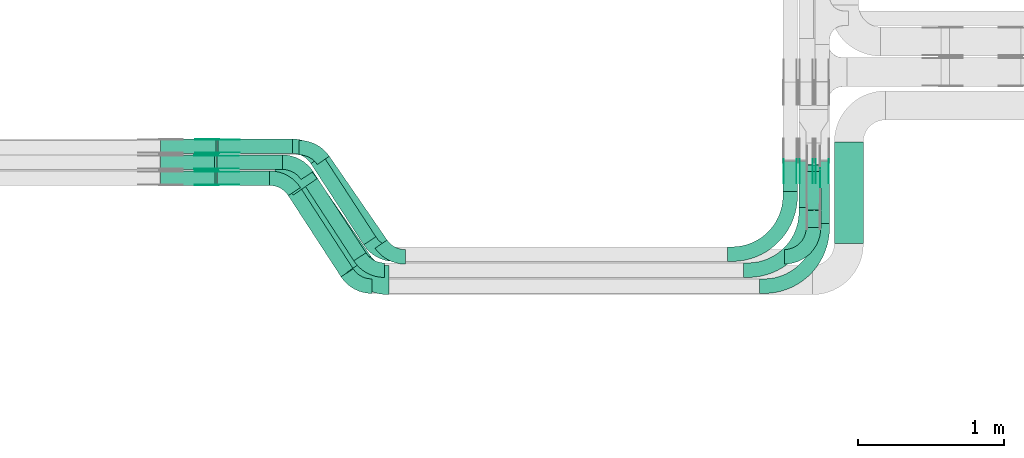
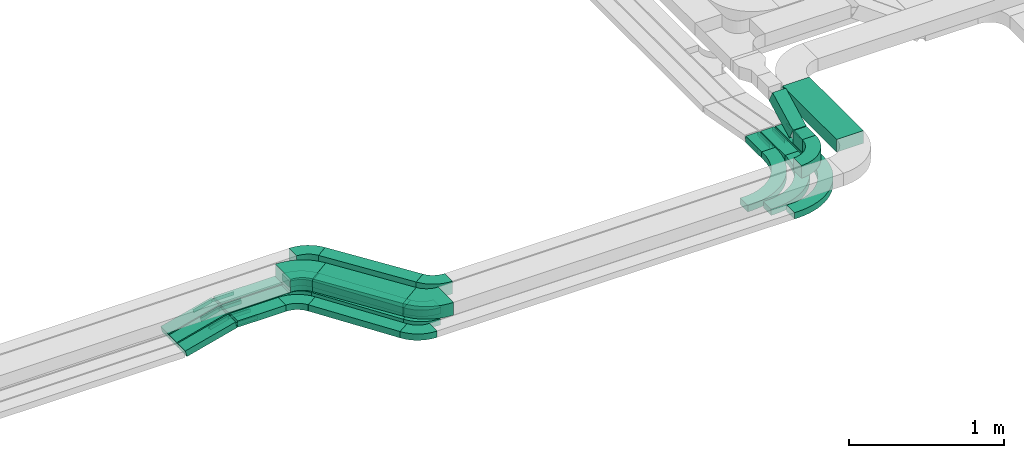
# One storey, part 9 of 23: 33 flow fittings, 17 flow segments.
"""IFC2X3 building model written with IfcOpenShell, lengths in millimetres."""

from ifc_helpers import new_model, entity, si_unit, converted_unit, derived_unit, direction, frame, frame_2d, origin, origin_2d_with_axis, place, context, subcontext, project, spatial, polyline, circle_curve, parameter, trimmed, segment, composite_curve, rectangle, outline, extrude, source, transform, mapped, material, type_object, type_shapes, element, save


model = new_model("IFC2X3")

# Units and contexts
model_context = context("Model", 3, precision=0.01, world=origin(), true_north=direction((6.12303176911189e-17, 1.0)))
body_context = subcontext(model_context, "Body", "Model", "MODEL_VIEW")
ifc_project = project(units=[si_unit("LENGTHUNIT", "METRE", prefix="MILLI"), si_unit("AREAUNIT", "SQUARE_METRE"), si_unit("VOLUMEUNIT", "CUBIC_METRE"), converted_unit("PLANEANGLEUNIT", "DEGREE", entity("IfcRatioMeasure", 0.0174532925199433), si_unit("PLANEANGLEUNIT", "RADIAN"), dimensions=[0, 0, 0, 0, 0, 0, 0]), si_unit("MASSUNIT", "GRAM", prefix="KILO"), derived_unit("MASSDENSITYUNIT", [(si_unit("MASSUNIT", "GRAM", prefix="KILO"), 1), (si_unit("LENGTHUNIT", "METRE"), -3)]), derived_unit("MOMENTOFINERTIAUNIT", [(si_unit("LENGTHUNIT", "METRE"), 4)]), si_unit("TIMEUNIT", "SECOND"), si_unit("FREQUENCYUNIT", "HERTZ"), si_unit("THERMODYNAMICTEMPERATUREUNIT", "DEGREE_CELSIUS"), derived_unit("THERMALTRANSMITTANCEUNIT", [(si_unit("MASSUNIT", "GRAM", prefix="KILO"), 1), (si_unit("THERMODYNAMICTEMPERATUREUNIT", "KELVIN"), -1), (si_unit("TIMEUNIT", "SECOND"), -3)]), derived_unit("VOLUMETRICFLOWRATEUNIT", [(si_unit("LENGTHUNIT", "METRE"), 3), (si_unit("TIMEUNIT", "SECOND"), -1)]), derived_unit("MASSFLOWRATEUNIT", [(si_unit("MASSUNIT", "GRAM", prefix="KILO"), 1), (si_unit("TIMEUNIT", "SECOND"), -1)]), derived_unit("ROTATIONALFREQUENCYUNIT", [(si_unit("TIMEUNIT", "SECOND"), -1)]), si_unit("ELECTRICCURRENTUNIT", "AMPERE"), si_unit("ELECTRICVOLTAGEUNIT", "VOLT"), si_unit("POWERUNIT", "WATT"), si_unit("FORCEUNIT", "NEWTON", prefix="KILO"), si_unit("ILLUMINANCEUNIT", "LUX"), si_unit("LUMINOUSFLUXUNIT", "LUMEN"), si_unit("LUMINOUSINTENSITYUNIT", "CANDELA"), derived_unit("USERDEFINED", [(si_unit("MASSUNIT", "GRAM", prefix="KILO"), -1), (si_unit("LENGTHUNIT", "METRE"), -2), (si_unit("TIMEUNIT", "SECOND"), 3), (si_unit("LUMINOUSFLUXUNIT", "LUMEN"), 1)]), derived_unit("LINEARVELOCITYUNIT", [(si_unit("LENGTHUNIT", "METRE"), 1), (si_unit("TIMEUNIT", "SECOND"), -1)]), si_unit("PRESSUREUNIT", "PASCAL"), derived_unit("USERDEFINED", [(si_unit("LENGTHUNIT", "METRE"), -2), (si_unit("MASSUNIT", "GRAM", prefix="KILO"), 1), (si_unit("TIMEUNIT", "SECOND"), -2)]), derived_unit("LINEARFORCEUNIT", [(si_unit("MASSUNIT", "GRAM", prefix="KILO"), 1), (si_unit("LENGTHUNIT", "METRE"), 1), (si_unit("TIMEUNIT", "SECOND"), -2), (si_unit("LENGTHUNIT", "METRE"), -1)]), derived_unit("PLANARFORCEUNIT", [(si_unit("MASSUNIT", "GRAM", prefix="KILO"), 1), (si_unit("LENGTHUNIT", "METRE"), 1), (si_unit("TIMEUNIT", "SECOND"), -2), (si_unit("LENGTHUNIT", "METRE"), -2)])], contexts=[model_context])

# Site, building, storey
site_placement = place(None, origin())
site = spatial("IfcSite", under=ifc_project, at=site_placement, CompositionType="ELEMENT")
building_placement = place(site_placement, origin())
building = spatial("IfcBuilding", under=site, at=building_placement, CompositionType="ELEMENT")
storey_placement = place(building_placement, frame((0.0, 0.0, 24000.0)))
storey = spatial("IfcBuildingStorey", under=building, at=storey_placement, CompositionType="ELEMENT", Elevation=24000.0)

# Flow segments
cable_carrier_segment_type = type_object("IfcCableCarrierSegmentType", PredefinedType="CABLETRAYSEGMENT")
flow_segment_1_placement = place(storey_placement, frame((28945.08, 10007.82, 2750.0)))
element("IfcFlowSegment", 1, at=flow_segment_1_placement, inside=storey, type_object=cable_carrier_segment_type, context=body_context, shape_type="SweptSolid", body=[
    extrude(rectangle(XDim=449.703961054591, YDim=99.9999999999989, at=origin_2d_with_axis()), frame((224.85, 50.0, 0.0)), (0.0, 0.0, 1.0), 49.9999999999931),
])
flow_segment_2_placement = place(storey_placement, frame((28952.89, 10117.82, 2750.0)))
element("IfcFlowSegment", 2, at=flow_segment_2_placement, inside=storey, type_object=cable_carrier_segment_type, context=body_context, shape_type="SweptSolid", body=[
    extrude(rectangle(XDim=509.777434753036, YDim=99.9999999999989, at=origin_2d_with_axis()), frame((254.89, 50.0, 0.0)), (0.0, 0.0, 1.0), 49.9999999999974),
])
flow_segment_3_placement = place(storey_placement, frame((29589.98, 9490.7, 2750.0)))
element("IfcFlowSegment", 3, at=flow_segment_3_placement, inside=storey, type_object=cable_carrier_segment_type, context=body_context, shape_type="SweptSolid", body=[
    extrude(rectangle(XDim=665.559579029172, YDim=100.000000000004, at=origin_2d_with_axis()), frame((223.28, 306.27, 0.0), z_axis=(5.11388203057767e-09, -7.86751081627487e-09, 1.0), x_axis=(0.544988350595341, -0.838443616300685, -9.38347035306593e-09)), (0.0, 0.0, 1.0), 49.9999999999973),
])
flow_segment_4_placement = place(storey_placement, frame((29634.49, 9466.73, 2890.0)))
element("IfcFlowSegment", 4, at=flow_segment_4_placement, inside=storey, type_object=cable_carrier_segment_type, context=body_context, shape_type="SweptSolid", body=[
    extrude(rectangle(XDim=698.971890855876, YDim=99.9999999999974, at=origin_2d_with_axis()), frame((239.56, 316.1, 0.0), z_axis=(0.0, 0.0, 1.0), x_axis=(0.567682967884993, -0.823247258102501, 0.0)), (0.0, 0.0, 1.0), 100.000000000003),
])
flow_segment_5_placement = place(storey_placement, frame((28948.31, 9897.82, 2750.0)))
element("IfcFlowSegment", 5, at=flow_segment_5_placement, inside=storey, type_object=cable_carrier_segment_type, context=body_context, shape_type="SweptSolid", body=[
    extrude(rectangle(XDim=359.081105196311, YDim=99.9999999999989, at=origin_2d_with_axis()), frame((179.54, 50.0, 0.0)), (0.0, 0.0, 1.0), 49.9999999999974),
])
flow_segment_6_placement = place(storey_placement, frame((29469.01, 9299.96, 2890.0)))
element("IfcFlowSegment", 6, at=flow_segment_6_placement, inside=storey, type_object=cable_carrier_segment_type, context=body_context, shape_type="SweptSolid", body=[
    extrude(rectangle(XDim=646.458259275562, YDim=199.999999999999, at=origin_2d_with_axis()), frame((265.82, 322.87, 0.0), z_axis=(0.0, 0.0, 1.0), x_axis=(0.567682967884968, -0.823247258102519, 0.0)), (0.0, 0.0, 1.0), 100.000000000003),
])
flow_segment_7_placement = place(storey_placement, frame((29434.7, 9270.7, 2750.0)))
element("IfcFlowSegment", 7, at=flow_segment_7_placement, inside=storey, type_object=cable_carrier_segment_type, context=body_context, shape_type="SweptSolid", body=[
    extrude(rectangle(XDim=665.559579029205, YDim=99.9999999999987, at=origin_2d_with_axis()), frame((223.28, 306.27, 0.0), z_axis=(5.22016867856222e-09, -8.03102873625081e-09, 1.0), x_axis=(0.544988350595353, -0.838443616300677, -9.57849589419594e-09)), (0.0, 0.0, 1.0), 50.0000000000016),
])
flow_segment_8_placement = place(storey_placement, frame((29522.09, 9380.7, 2750.0)))
element("IfcFlowSegment", 8, at=flow_segment_8_placement, inside=storey, type_object=cable_carrier_segment_type, context=body_context, shape_type="SweptSolid", body=[
    extrude(rectangle(XDim=665.559579029195, YDim=99.9999999999999, at=origin_2d_with_axis()), frame((223.28, 306.27, 0.0), z_axis=(5.15245691573413e-09, -7.9268567934381e-09, 1.0), x_axis=(0.544988350595368, -0.838443616300667, -9.4542514718074e-09)), (0.0, 0.0, 1.0), 49.9999999999973),
])
flow_segment_9_placement = place(storey_placement, frame((28557.66, 9897.82, 2651.99)))
element("IfcFlowSegment", 9, at=flow_segment_9_placement, inside=storey, type_object=cable_carrier_segment_type, context=body_context, shape_type="SweptSolid", body=[
    extrude(rectangle(XDim=49.9999999999986, YDim=99.9999999999989, at=origin_2d_with_axis()), frame((6.3, 50.0, 24.19), z_axis=(0.967755764973787, 0.0, 0.251890411409408), x_axis=(-0.251890411409408, 0.0, 0.967755764973787)), (0.0, 0.0, 1.0), 387.573437364003),
])
flow_segment_10_placement = place(storey_placement, frame((28557.64, 10007.82, 2652.02)))
element("IfcFlowSegment", 10, at=flow_segment_10_placement, inside=storey, type_object=cable_carrier_segment_type, context=body_context, shape_type="SweptSolid", body=[
    extrude(rectangle(XDim=49.9999999999973, YDim=99.9999999999989, at=origin_2d_with_axis()), frame((6.35, 50.0, 24.18), z_axis=(0.967228406139617, 0.0, 0.253907877697044), x_axis=(-0.253907877697044, 0.0, 0.967228406139617)), (0.0, 0.0, 1.0), 384.355490296213),
])
flow_segment_11_placement = place(storey_placement, frame((28557.7, 10117.82, 2651.95)))
element("IfcFlowSegment", 11, at=flow_segment_11_placement, inside=storey, type_object=cable_carrier_segment_type, context=body_context, shape_type="SweptSolid", body=[
    extrude(rectangle(XDim=50.0000000000031, YDim=99.9999999999989, at=origin_2d_with_axis()), frame((6.23, 50.0, 24.21), z_axis=(0.968482292861, 0.0, 0.249082412897219), x_axis=(-0.249082412897219, 0.0, 0.968482292861)), (0.0, 0.0, 1.0), 392.132317558253),
])
flow_segment_12_placement = place(storey_placement, frame((33053.08, 9636.11, 2750.0)))
element("IfcFlowSegment", 12, at=flow_segment_12_placement, inside=storey, type_object=cable_carrier_segment_type, context=body_context, shape_type="SweptSolid", body=[
    extrude(rectangle(XDim=426.077042321789, YDim=100.000000000003, at=origin_2d_with_axis()), frame((50.0, 213.04, 0.0), z_axis=(0.0, 0.0, 1.0), x_axis=(0.0, -1.0, 0.0)), (0.0, 0.0, 1.0), 49.9999999999973),
])
flow_segment_13_placement = place(storey_placement, frame((32943.08, 9746.11, 2750.0)))
element("IfcFlowSegment", 13, at=flow_segment_13_placement, inside=storey, type_object=cable_carrier_segment_type, context=body_context, shape_type="SweptSolid", body=[
    extrude(rectangle(XDim=316.077042321782, YDim=100.000000000003, at=origin_2d_with_axis()), frame((50.0, 158.04, 0.0), z_axis=(0.0, 0.0, 1.0), x_axis=(0.0, 1.0, 0.0)), (0.0, 0.0, 1.0), 49.9999999999973),
])
flow_segment_14_placement = place(storey_placement, frame((32833.08, 9856.11, 2750.0)))
element("IfcFlowSegment", 14, at=flow_segment_14_placement, inside=storey, type_object=cable_carrier_segment_type, context=body_context, shape_type="SweptSolid", body=[
    extrude(rectangle(XDim=206.07704232179, YDim=100.000000000003, at=origin_2d_with_axis()), frame((50.0, 103.04, 0.0), z_axis=(0.0, 0.0, 1.0), x_axis=(0.0, -1.0, 0.0)), (0.0, 0.0, 1.0), 49.9999999999973),
])
flow_segment_15_placement = place(storey_placement, frame((32993.08, 9608.82, 2890.0)))
element("IfcFlowSegment", 15, at=flow_segment_15_placement, inside=storey, type_object=cable_carrier_segment_type, context=body_context, shape_type="SweptSolid", body=[
    extrude(rectangle(XDim=116.82449845036, YDim=100.000000000003, at=origin_2d_with_axis()), frame((50.0, 58.41, 0.0), z_axis=(0.0, 0.0, 1.0), x_axis=(0.0, 1.0, 0.0)), (0.0, 0.0, 1.0), 100.000000000003),
])
flow_segment_16_placement = place(storey_placement, frame((32993.08, 9729.38, 2902.16)))
element("IfcFlowSegment", 16, at=flow_segment_16_placement, inside=storey, type_object=cable_carrier_segment_type, context=body_context, shape_type="SweptSolid", body=[
    extrude(rectangle(XDim=100.000000000008, YDim=100.000000000003, at=origin_2d_with_axis()), frame((50.0, 23.04, 44.37), z_axis=(0.0, 0.887490575455865, 0.460825865677067), x_axis=(0.0, -0.460825865677067, 0.887490575455865)), (0.0, 0.0, 1.0), 297.134645895809),
])
flow_segment_17_placement = place(storey_placement, frame((33185.89, 9498.82, 2890.0)))
element("IfcFlowSegment", 17, at=flow_segment_17_placement, inside=storey, type_object=cable_carrier_segment_type, context=body_context, shape_type="SweptSolid", body=[
    extrude(rectangle(XDim=698.000000000018, YDim=199.999999999998, at=origin_2d_with_axis()), frame((100.0, 349.0, 0.0), z_axis=(0.0, 0.0, 1.0), x_axis=(0.0, 1.0, 0.0)), (0.0, 0.0, 1.0), 100.000000000003),
])

# Flow fittings
ifc_material_1 = material(Name="G")
cable_carrier_fitting_type_1 = type_object("IfcCableCarrierFittingType", PredefinedType="NOTDEFINED", material=ifc_material_1)
shared_shape_1 = source(origin(), body_context, "Body", "SweptSolid", [
    extrude(outline(composite_curve([segment(trimmed(circle_curve(frame_2d((-44.59, 0.0), x_axis=(1.0, 0.0)), 12.5), [parameter(90.0000000000007)], [parameter(270.0)], True, "PARAMETER"), True, "CONTINUOUS"), segment(polyline([(-44.59, -12.5), (-33.09, -12.5)]), True, "CONTINUOUS"), segment(polyline([(-33.09, -12.5), (-31.23, -14.5)]), True, "CONTINUOUS"), segment(polyline([(-31.23, -14.5), (108.91, -14.5)]), True, "CONTINUOUS"), segment(polyline([(108.91, -14.5), (108.91, 14.5)]), True, "CONTINUOUS"), segment(polyline([(108.91, 14.5), (-31.23, 14.5)]), True, "CONTINUOUS"), segment(polyline([(-31.23, 14.5), (-33.09, 12.5)]), True, "CONTINUOUS"), segment(polyline([(-33.09, 12.5), (-44.59, 12.5)]), True, "CONTINUOUS")], self_intersect=False)), frame((44.59, 0.0, 0.0), z_axis=(0.0, 0.0, -1.0), x_axis=(1.0, 0.0, 0.0)), (0.0, 0.0, -1.0), 2.0),
])
type_shapes(cable_carrier_fitting_type_1, [shared_shape_1])
flow_fitting_1_placement = place(storey_placement, frame((28943.6, 9902.36, 2775.0), z_axis=(0.0, -1.0, 0.0), x_axis=(-0.96775576497502, 0.0, -0.251890411404671)))
element("IfcFlowFitting", 18, at=flow_fitting_1_placement, inside=storey, type_object=cable_carrier_fitting_type_1, material=ifc_material_1, context=body_context, shape_type="MappedRepresentation", body=[
    mapped(shared_shape_1, transform((0.0, 0.0, 0.0), scale=1.0)),
])
cable_carrier_fitting_type_2 = type_object("IfcCableCarrierFittingType", PredefinedType="NOTDEFINED", material=ifc_material_1)
type_shapes(cable_carrier_fitting_type_2, [shared_shape_1])
flow_fitting_2_placement = place(storey_placement, frame((28943.6, 9991.28, 2775.0), z_axis=(0.0, 1.0, 0.0), x_axis=(1.0, 0.0, 5.81999550691969e-08)))
element("IfcFlowFitting", 19, at=flow_fitting_2_placement, inside=storey, type_object=cable_carrier_fitting_type_2, material=ifc_material_1, context=body_context, shape_type="MappedRepresentation", body=[
    mapped(shared_shape_1, transform((0.0, 0.0, 0.0), scale=1.0)),
])
flow_fitting_3_placement = place(storey_placement, frame((28940.34, 10012.36, 2775.0), z_axis=(0.0, -1.0, 0.0), x_axis=(-0.967228406140868, 0.0, -0.253907877692276)))
element("IfcFlowFitting", 20, at=flow_fitting_3_placement, inside=storey, type_object=cable_carrier_fitting_type_1, material=ifc_material_1, context=body_context, shape_type="MappedRepresentation", body=[
    mapped(shared_shape_1, transform((0.0, 0.0, 0.0), scale=1.0)),
])
flow_fitting_4_placement = place(storey_placement, frame((28940.34, 10101.28, 2775.0), z_axis=(0.0, 1.0, 0.0), x_axis=(1.0, 0.0, 5.74450136485811e-08)))
element("IfcFlowFitting", 21, at=flow_fitting_4_placement, inside=storey, type_object=cable_carrier_fitting_type_2, material=ifc_material_1, context=body_context, shape_type="MappedRepresentation", body=[
    mapped(shared_shape_1, transform((0.0, 0.0, 0.0), scale=1.0)),
])
flow_fitting_5_placement = place(storey_placement, frame((28948.22, 10122.36, 2775.0), z_axis=(0.0, -1.0, 0.0), x_axis=(-0.968482292862194, 0.0, -0.249082412892576)))
element("IfcFlowFitting", 22, at=flow_fitting_5_placement, inside=storey, type_object=cable_carrier_fitting_type_1, material=ifc_material_1, context=body_context, shape_type="MappedRepresentation", body=[
    mapped(shared_shape_1, transform((0.0, 0.0, 0.0), scale=1.0)),
])
for number, where, z_axis, x_axis in (
    (23, (28948.22, 10211.28, 2775.0), (0.0, 1.0, 0.0), (1.0, 0.0, 5.70149555300472e-08)),
    (24, (32926.54, 10065.84, 2775.0), (1.0, 0.0, 0.0), (0.0, -1.0, 0.0)),
    (25, (33036.54, 10065.84, 2775.0), (1.0, 0.0, 0.0), (0.0, -1.0, 0.0)),
    (26, (33146.54, 10065.84, 2775.0), (1.0, 0.0, 0.0), (0.0, -1.0, 0.0)),
):
    element("IfcFlowFitting", number, at=place(storey_placement, frame(where, z_axis=z_axis, x_axis=x_axis)), inside=storey, type_object=cable_carrier_fitting_type_2, material=ifc_material_1, context=body_context, shape_type="MappedRepresentation", body=[
        mapped(shared_shape_1, transform((0.0, 0.0, 0.0), scale=1.0)),
    ])
cable_carrier_fitting_type_3 = type_object("IfcCableCarrierFittingType", PredefinedType="NOTDEFINED", material=ifc_material_1)
shared_shape_2 = source(origin(), body_context, "Body", "SweptSolid", [
    extrude(outline(composite_curve([segment(trimmed(circle_curve(frame_2d((-44.59, 0.0), x_axis=(1.0, 0.0)), 12.5), [parameter(90.0000000000007)], [parameter(270.0)], True, "PARAMETER"), True, "CONTINUOUS"), segment(polyline([(-44.59, -12.5), (-33.09, -12.5)]), True, "CONTINUOUS"), segment(polyline([(-33.09, -12.5), (-31.23, -14.5)]), True, "CONTINUOUS"), segment(polyline([(-31.23, -14.5), (108.91, -14.5)]), True, "CONTINUOUS"), segment(polyline([(108.91, -14.5), (108.91, 14.5)]), True, "CONTINUOUS"), segment(polyline([(108.91, 14.5), (-31.23, 14.5)]), True, "CONTINUOUS"), segment(polyline([(-31.23, 14.5), (-33.09, 12.5)]), True, "CONTINUOUS"), segment(polyline([(-33.09, 12.5), (-44.59, 12.5)]), True, "CONTINUOUS")], self_intersect=False)), frame((44.59, 0.0, 0.0)), (0.0, 0.0, 1.0), 2.0),
])
type_shapes(cable_carrier_fitting_type_3, [shared_shape_2])
flow_fitting_6_placement = place(storey_placement, frame((28943.6, 9993.28, 2775.0), z_axis=(0.0, 1.0, 0.0), x_axis=(-0.96775576497502, 0.0, -0.251890411404671)))
element("IfcFlowFitting", 27, at=flow_fitting_6_placement, inside=storey, type_object=cable_carrier_fitting_type_3, material=ifc_material_1, context=body_context, shape_type="MappedRepresentation", body=[
    mapped(shared_shape_2, transform((0.0, 0.0, 0.0), scale=1.0)),
])
cable_carrier_fitting_type_4 = type_object("IfcCableCarrierFittingType", PredefinedType="NOTDEFINED", material=ifc_material_1)
type_shapes(cable_carrier_fitting_type_4, [shared_shape_2])
flow_fitting_7_placement = place(storey_placement, frame((28943.6, 9904.36, 2775.0), z_axis=(0.0, -1.0, 0.0), x_axis=(1.0, 0.0, 5.81999550691969e-08)))
element("IfcFlowFitting", 28, at=flow_fitting_7_placement, inside=storey, type_object=cable_carrier_fitting_type_4, material=ifc_material_1, context=body_context, shape_type="MappedRepresentation", body=[
    mapped(shared_shape_2, transform((0.0, 0.0, 0.0), scale=1.0)),
])
flow_fitting_8_placement = place(storey_placement, frame((28940.34, 10103.28, 2775.0), z_axis=(0.0, 1.0, 0.0), x_axis=(-0.967228406140868, 0.0, -0.253907877692276)))
element("IfcFlowFitting", 29, at=flow_fitting_8_placement, inside=storey, type_object=cable_carrier_fitting_type_3, material=ifc_material_1, context=body_context, shape_type="MappedRepresentation", body=[
    mapped(shared_shape_2, transform((0.0, 0.0, 0.0), scale=1.0)),
])
flow_fitting_9_placement = place(storey_placement, frame((28940.34, 10014.36, 2775.0), z_axis=(0.0, -1.0, 0.0), x_axis=(1.0, 0.0, 5.74450136485811e-08)))
element("IfcFlowFitting", 30, at=flow_fitting_9_placement, inside=storey, type_object=cable_carrier_fitting_type_4, material=ifc_material_1, context=body_context, shape_type="MappedRepresentation", body=[
    mapped(shared_shape_2, transform((0.0, 0.0, 0.0), scale=1.0)),
])
flow_fitting_10_placement = place(storey_placement, frame((28948.22, 10213.28, 2775.0), z_axis=(0.0, 1.0, 0.0), x_axis=(-0.968482292862194, 0.0, -0.249082412892576)))
element("IfcFlowFitting", 31, at=flow_fitting_10_placement, inside=storey, type_object=cable_carrier_fitting_type_3, material=ifc_material_1, context=body_context, shape_type="MappedRepresentation", body=[
    mapped(shared_shape_2, transform((0.0, 0.0, 0.0), scale=1.0)),
])
for number, where, z_axis, x_axis in (
    (32, (28948.22, 10124.36, 2775.0), (0.0, -1.0, 0.0), (1.0, 0.0, 5.70149555300472e-08)),
    (33, (32839.62, 10065.84, 2775.0), (-1.0, 0.0, 0.0), (0.0, -1.0, 0.0)),
    (34, (32949.62, 10065.84, 2775.0), (-1.0, 0.0, 0.0), (0.0, -1.0, 0.0)),
    (35, (33059.62, 10065.84, 2775.0), (-1.0, 0.0, 0.0), (0.0, -1.0, 0.0)),
):
    element("IfcFlowFitting", number, at=place(storey_placement, frame(where, z_axis=z_axis, x_axis=x_axis)), inside=storey, type_object=cable_carrier_fitting_type_4, material=ifc_material_1, context=body_context, shape_type="MappedRepresentation", body=[
        mapped(shared_shape_2, transform((0.0, 0.0, 0.0), scale=1.0)),
    ])
ifc_material_2 = material()
cable_carrier_fitting_type_5 = type_object("IfcCableCarrierFittingType", Name="470_DKC_S5_Variable Angle Elbow 0-45:-", PredefinedType="NOTDEFINED", material=ifc_material_2)
shared_shape_3 = source(origin(), body_context, "Body", "SweptSolid", [
    extrude(outline(composite_curve([segment(polyline([(-100.75, -150.25), (-99.75, -150.25)]), True, "CONTINUOUS"), segment(trimmed(circle_curve(frame_2d((-99.75, 99.75), x_axis=(0.0, -1.0)), 250.0), [parameter(0.0)], [parameter(90.0000000000001)], True, "PARAMETER"), True, "CONTINUOUS"), segment(polyline([(150.25, 99.75), (150.25, 100.75)]), True, "CONTINUOUS"), segment(polyline([(150.25, 100.75), (50.25, 100.75)]), True, "CONTINUOUS"), segment(polyline([(50.25, 100.75), (50.25, 99.75)]), True, "CONTINUOUS"), segment(trimmed(circle_curve(frame_2d((-99.75, 99.75), x_axis=(0.0, -1.0)), 150.0), [parameter(0.0)], [parameter(90.0000000000001)], True, "PARAMETER"), False, "CONTINUOUS"), segment(polyline([(-99.75, -50.25), (-100.75, -50.25)]), True, "CONTINUOUS"), segment(polyline([(-100.75, -50.25), (-100.75, -150.25)]), True, "CONTINUOUS")], self_intersect=False)), frame((-100.25, 100.25, -50.0)), (0.0, 0.0, 1.0), 100.0),
])
type_shapes(cable_carrier_fitting_type_5, [shared_shape_3])
flow_fitting_11_placement = place(storey_placement, frame((33043.08, 9407.82, 2940.0)))
element("IfcFlowFitting", 36, at=flow_fitting_11_placement, inside=storey, type_object=cable_carrier_fitting_type_5, material=ifc_material_2, Name="470_DKC_S5_Variable Angle Elbow 0-45:-", ObjectType="470_DKC_S5_Variable Angle Elbow 0-45:-", context=body_context, shape_type="MappedRepresentation", body=[
    mapped(shared_shape_3, transform((0.0, 0.0, 0.0), scale=1.0)),
])
cable_carrier_fitting_type_6 = type_object("IfcCableCarrierFittingType", PredefinedType="NOTDEFINED", material=ifc_material_1)
shared_shape_4 = source(origin(), body_context, "Body", "SweptSolid", [
    extrude(outline(composite_curve([segment(trimmed(circle_curve(frame_2d((-41.47, 0.0), x_axis=(1.0, 0.0)), 25.0), [parameter(90.0000000000007)], [parameter(270.0)], True, "PARAMETER"), True, "CONTINUOUS"), segment(polyline([(-41.47, -25.0), (-29.97, -25.0)]), True, "CONTINUOUS"), segment(polyline([(-29.97, -25.0), (-28.1, -38.5)]), True, "CONTINUOUS"), segment(polyline([(-28.1, -38.5), (99.53, -38.5)]), True, "CONTINUOUS"), segment(polyline([(99.53, -38.5), (99.53, 38.5)]), True, "CONTINUOUS"), segment(polyline([(99.53, 38.5), (-28.1, 38.5)]), True, "CONTINUOUS"), segment(polyline([(-28.1, 38.5), (-29.97, 25.0)]), True, "CONTINUOUS"), segment(polyline([(-29.97, 25.0), (-41.47, 25.0)]), True, "CONTINUOUS")], self_intersect=False)), frame((41.47, 0.0, 0.0), z_axis=(0.0, 0.0, -1.0), x_axis=(1.0, 0.0, 0.0)), (0.0, 0.0, -1.0), 2.0),
])
type_shapes(cable_carrier_fitting_type_6, [shared_shape_4])
flow_fitting_12_placement = place(storey_placement, frame((33088.54, 10028.71, 3090.0), z_axis=(1.0, 0.0, 0.0), x_axis=(0.0, -0.887490575455891, -0.460825865677017)))
element("IfcFlowFitting", 37, at=flow_fitting_12_placement, inside=storey, type_object=cable_carrier_fitting_type_6, material=ifc_material_1, context=body_context, shape_type="MappedRepresentation", body=[
    mapped(shared_shape_4, transform((0.0, 0.0, 0.0), scale=1.0)),
])
cable_carrier_fitting_type_7 = type_object("IfcCableCarrierFittingType", Name="470_DKC_S5_Variable Angle Elbow 0-45:-", PredefinedType="NOTDEFINED", material=ifc_material_2)
shared_shape_5 = source(origin(), body_context, "Body", "SweptSolid", [
    extrude(outline(composite_curve([segment(polyline([(-83.22, -93.44), (-82.22, -93.44)]), True, "CONTINUOUS"), segment(trimmed(circle_curve(frame_2d((-82.22, 156.56), x_axis=(0.0, -1.0)), 250.0), [parameter(0.0)], [parameter(55.4111904090834)], True, "PARAMETER"), True, "CONTINUOUS"), segment(polyline([(123.6, 14.64), (124.16, 15.46)]), True, "CONTINUOUS"), segment(polyline([(124.16, 15.46), (41.84, 72.23)]), True, "CONTINUOUS"), segment(polyline([(41.84, 72.23), (41.27, 71.41)]), True, "CONTINUOUS"), segment(trimmed(circle_curve(frame_2d((-82.22, 156.56), x_axis=(0.0, -1.0)), 150.0), [parameter(0.0)], [parameter(55.4111904090834)], True, "PARAMETER"), False, "CONTINUOUS"), segment(polyline([(-82.22, 6.56), (-83.22, 6.56)]), True, "CONTINUOUS"), segment(polyline([(-83.22, 6.56), (-83.22, -93.44)]), True, "CONTINUOUS")], self_intersect=False)), frame((-22.81, 43.44, -50.0)), (0.0, 0.0, 1.0), 100.0),
])
type_shapes(cable_carrier_fitting_type_7, [shared_shape_5])
for number, where, z_axis, x_axis, name in (
    (38, (29615.46, 10157.82, 2940.0), (0.0, 0.0, 1.0), (-0.567682967884992, 0.823247258102502, 0.0), "470_DKC_S5_Variable Angle Elbow 0-45:-"),
    (39, (30132.64, 9407.82, 2940.0), (0.0, 0.0, 1.0), (0.567682967884987, -0.823247258102505, 0.0), "470_DKC_S5_Variable Angle Elbow 0-45:-"),
):
    element("IfcFlowFitting", number, at=place(storey_placement, frame(where, z_axis=z_axis, x_axis=x_axis)), inside=storey, type_object=cable_carrier_fitting_type_7, material=ifc_material_2, Name=name, ObjectType="470_DKC_S5_Variable Angle Elbow 0-45:-", context=body_context, shape_type="MappedRepresentation", body=[
        mapped(shared_shape_5, transform((0.0, 0.0, 0.0), scale=1.0)),
    ])
cable_carrier_fitting_type_8 = type_object("IfcCableCarrierFittingType", Name="470_DKC_S5_Variable Angle Elbow 0-45:-", PredefinedType="NOTDEFINED", material=ifc_material_2)
shared_shape_6 = source(origin(), body_context, "Body", "SweptSolid", [
    extrude(outline(composite_curve([segment(polyline([(-103.8, -154.25), (-102.8, -154.25)]), True, "CONTINUOUS"), segment(trimmed(circle_curve(frame_2d((-102.8, 195.75), x_axis=(0.0, -1.0)), 350.0), [parameter(0.0)], [parameter(55.411190409084)], True, "PARAMETER"), True, "CONTINUOUS"), segment(polyline([(185.34, -2.93), (185.91, -2.11)]), True, "CONTINUOUS"), segment(polyline([(185.91, -2.11), (21.26, 111.43)]), True, "CONTINUOUS"), segment(polyline([(21.26, 111.43), (20.69, 110.6)]), True, "CONTINUOUS"), segment(trimmed(circle_curve(frame_2d((-102.8, 195.75), x_axis=(0.0, -1.0)), 150.0), [parameter(0.0)], [parameter(55.411190409084)], True, "PARAMETER"), False, "CONTINUOUS"), segment(polyline([(-102.8, 45.75), (-103.8, 45.75)]), True, "CONTINUOUS"), segment(polyline([(-103.8, 45.75), (-103.8, -154.25)]), True, "CONTINUOUS")], self_intersect=False)), frame((-28.49, 54.25, -50.0)), (0.0, 0.0, 1.0), 100.0),
])
type_shapes(cable_carrier_fitting_type_8, [shared_shape_6])
for number, where, z_axis, x_axis, name in (
    (40, (29476.24, 9997.82, 2940.0), (0.0, 0.0, 1.0), (-0.56768296788499, 0.823247258102503, 0.0), "470_DKC_S5_Variable Angle Elbow 0-45:-"),
    (41, (29993.42, 9247.82, 2940.0), (0.0, 0.0, 1.0), (0.567682967884968, -0.823247258102519, 0.0), "470_DKC_S5_Variable Angle Elbow 0-45:-"),
):
    element("IfcFlowFitting", number, at=place(storey_placement, frame(where, z_axis=z_axis, x_axis=x_axis)), inside=storey, type_object=cable_carrier_fitting_type_8, material=ifc_material_2, Name=name, ObjectType="470_DKC_S5_Variable Angle Elbow 0-45:-", context=body_context, shape_type="MappedRepresentation", body=[
        mapped(shared_shape_6, transform((0.0, 0.0, 0.0), scale=1.0)),
    ])
cable_carrier_fitting_type_9 = type_object("IfcCableCarrierFittingType", Name="470_DKC_S5_Variable Angle Elbow 0-45:-", PredefinedType="NOTDEFINED", material=ifc_material_2)
shared_shape_7 = source(origin(), body_context, "Body", "SweptSolid", [
    extrude(outline(composite_curve([segment(polyline([(-84.73, -95.71), (-83.73, -95.71)]), True, "CONTINUOUS"), segment(trimmed(circle_curve(frame_2d((-83.73, 154.29), x_axis=(0.0, -1.0)), 250.0), [parameter(0.0)], [parameter(56.9761324442035)], True, "PARAMETER"), True, "CONTINUOUS"), segment(polyline([(125.88, 18.04), (126.43, 18.88)]), True, "CONTINUOUS"), segment(polyline([(126.43, 18.88), (42.58, 73.38)]), True, "CONTINUOUS"), segment(polyline([(42.58, 73.38), (42.04, 72.54)]), True, "CONTINUOUS"), segment(trimmed(circle_curve(frame_2d((-83.73, 154.29), x_axis=(0.0, -1.0)), 150.0), [parameter(0.0)], [parameter(56.9761324442035)], True, "PARAMETER"), False, "CONTINUOUS"), segment(polyline([(-83.73, 4.29), (-84.73, 4.29)]), True, "CONTINUOUS"), segment(polyline([(-84.73, 4.29), (-84.73, -95.71)]), True, "CONTINUOUS")], self_intersect=False)), frame((-24.81, 45.71, -25.0)), (0.0, 0.0, 1.0), 49.9999999999998),
])
type_shapes(cable_carrier_fitting_type_9, [shared_shape_7])
for number, where, z_axis, x_axis, name in (
    (42, (29572.2, 10167.82, 2775.0), (-5.70149492850431e-08, -3.70597170352731e-08, 1.0), (-0.544988350595363, 0.83844361630067, 0.0), "470_DKC_S5_Variable Angle Elbow 0-45:-"),
    (43, (29504.32, 10057.82, 2775.0), (-5.74450074035765e-08, -3.73392548123228e-08, 1.0), (-0.544988350595394, 0.83844361630065, 0.0), "470_DKC_S5_Variable Angle Elbow 0-45:-"),
    (44, (29416.93, 9947.82, 2775.0), (-5.81999488241923e-08, -3.78299667357214e-08, 1.0), (-0.544988350595377, 0.838443616300661, 0.0), "470_DKC_S5_Variable Angle Elbow 0-45:-"),
    (45, (30054.32, 9426.11, 2775.0), (0.0, 0.0, 1.0), (0.544988350595342, -0.838443616300684, 0.0), "470_DKC_S5_Variable Angle Elbow 0-45:-"),
    (46, (29986.44, 9316.11, 2775.0), (0.0, 0.0, 1.0), (0.544988350595373, -0.838443616300664, 0.0), "470_DKC_S5_Variable Angle Elbow 0-45:-"),
    (47, (29899.04, 9206.11, 2775.0), (0.0, 0.0, 1.0), (0.544988350595354, -0.838443616300676, 0.0), "470_DKC_S5_Variable Angle Elbow 0-45:-"),
):
    element("IfcFlowFitting", number, at=place(storey_placement, frame(where, z_axis=z_axis, x_axis=x_axis)), inside=storey, type_object=cable_carrier_fitting_type_9, material=ifc_material_2, Name=name, ObjectType="470_DKC_S5_Variable Angle Elbow 0-45:-", context=body_context, shape_type="MappedRepresentation", body=[
        mapped(shared_shape_7, transform((0.0, 0.0, 0.0), scale=1.0)),
    ])
cable_carrier_fitting_type_10 = type_object("IfcCableCarrierFittingType", Name="470_DKC_S5_CPO 45 horizontal angle:-", PredefinedType="NOTDEFINED", material=ifc_material_2)
shared_shape_8 = source(origin(), body_context, "Body", "SweptSolid", [
    extrude(outline(composite_curve([segment(polyline([(-222.5, -257.5), (-192.5, -257.5)]), True, "CONTINUOUS"), segment(trimmed(circle_curve(frame_2d((-192.5, 192.5), x_axis=(0.0, -1.0)), 450.0), [parameter(0.0)], [parameter(90.0)], True, "PARAMETER"), True, "CONTINUOUS"), segment(polyline([(257.5, 192.5), (257.5, 222.5)]), True, "CONTINUOUS"), segment(polyline([(257.5, 222.5), (157.5, 222.5)]), True, "CONTINUOUS"), segment(polyline([(157.5, 222.5), (157.5, 192.5)]), True, "CONTINUOUS"), segment(trimmed(circle_curve(frame_2d((-192.5, 192.5), x_axis=(0.0, -1.0)), 350.0), [parameter(0.0)], [parameter(90.0)], True, "PARAMETER"), False, "CONTINUOUS"), segment(polyline([(-192.5, -157.5), (-222.5, -157.5)]), True, "CONTINUOUS"), segment(polyline([(-222.5, -157.5), (-222.5, -257.5)]), True, "CONTINUOUS")], self_intersect=False)), frame((-207.5, 207.5, -25.0)), (0.0, 0.0, 1.0), 50.0000000000002),
])
type_shapes(cable_carrier_fitting_type_10, [shared_shape_8])
for number, where, name in (
    (48, (32883.08, 9426.11, 2775.0), "470_DKC_S5_45 horizontal angle"),
    (49, (32993.08, 9316.11, 2775.0), "470_DKC_S5_45 horizontal angle"),
    (50, (33103.08, 9206.11, 2775.0), "470_DKC_S5_45 horizontal angle"),
):
    element("IfcFlowFitting", number, at=place(storey_placement, frame(where)), inside=storey, type_object=cable_carrier_fitting_type_10, material=ifc_material_2, Name=name, ObjectType="470_DKC_S5_CPO 45 horizontal angle:-", context=body_context, shape_type="MappedRepresentation", body=[
        mapped(shared_shape_8, transform((0.0, 0.0, 0.0), scale=1.0)),
    ])

save(model, "model.ifc")
